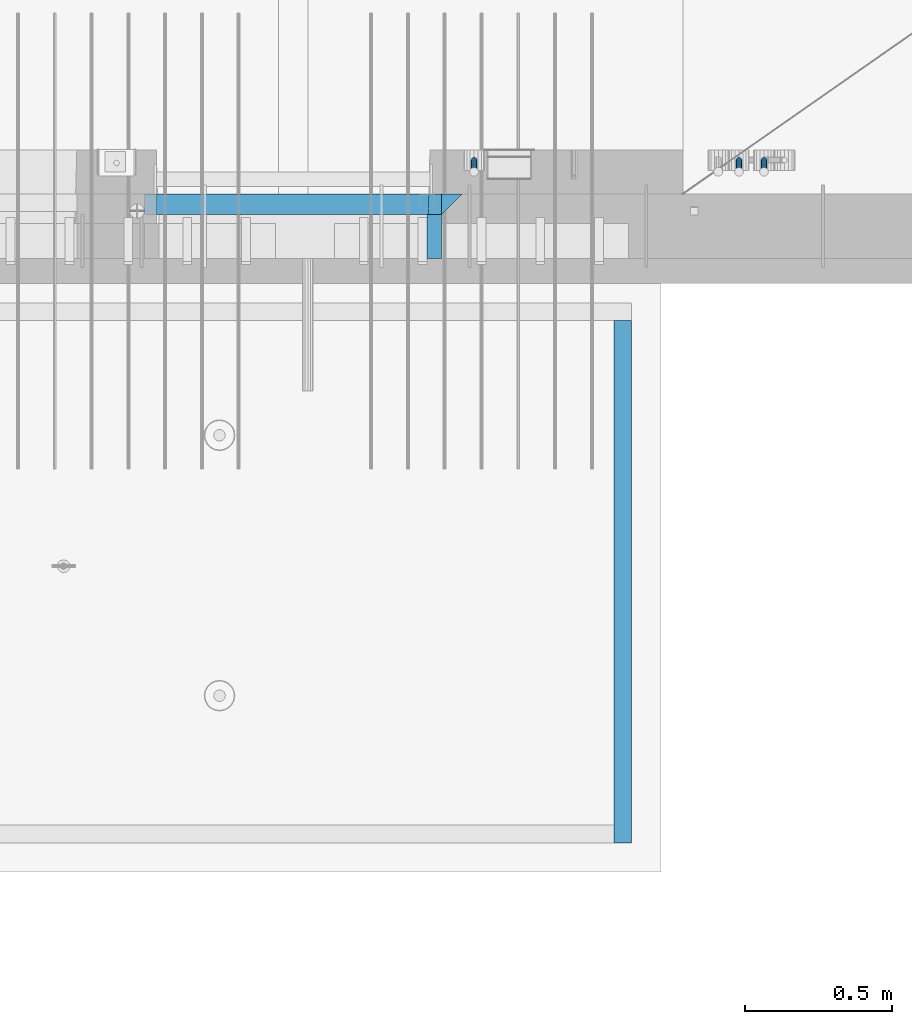
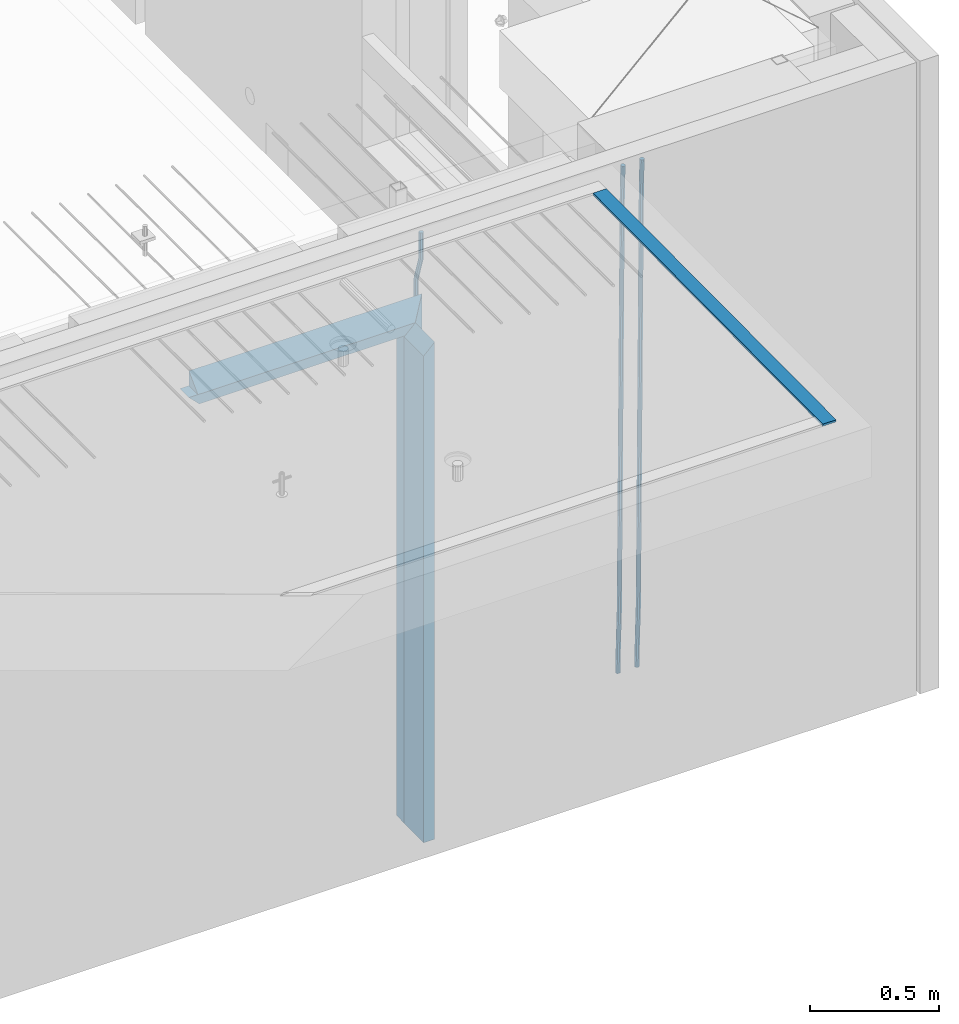
# One storey, part 123 of 334: 9 beams, 2 elements without a shape of their own.
"""IFC2X3 building model written with IfcOpenShell, lengths in millimetres."""

from ifc_helpers import new_model, si_unit, frame, origin_with_axes, place, context, subcontext, project, spatial, faceted_brep, material, type_object, element, aggregate, save


model = new_model("IFC2X3")

# Units and contexts
model_context = context("Model", 3, precision=1e-05, world=origin_with_axes())
body_context = subcontext(model_context, "Body", "Model", "MODEL_VIEW")
ifc_project = project(units=[si_unit("LENGTHUNIT", "METRE", prefix="MILLI"), si_unit("AREAUNIT", "SQUARE_METRE"), si_unit("VOLUMEUNIT", "CUBIC_METRE"), si_unit("MASSUNIT", "GRAM", prefix="KILO"), si_unit("TIMEUNIT", "SECOND"), si_unit("PLANEANGLEUNIT", "RADIAN"), si_unit("SOLIDANGLEUNIT", "STERADIAN"), si_unit("THERMODYNAMICTEMPERATUREUNIT", "DEGREE_CELSIUS"), si_unit("LUMINOUSINTENSITYUNIT", "LUMEN")], contexts=[model_context])

# Site, building, storey
site_placement = place(None, origin_with_axes())
site = spatial("IfcSite", under=ifc_project, at=site_placement, CompositionType="ELEMENT")
building_placement = place(site_placement, origin_with_axes())
building = spatial("IfcBuilding", under=site, at=building_placement, CompositionType="ELEMENT")
storey_placement = place(building_placement, origin_with_axes())
storey = spatial("IfcBuildingStorey", under=building, at=storey_placement, Name="3", CompositionType="ELEMENT", Elevation=0.0)

# Assembly, beams
assembly_1_placement = place(storey_placement, origin_with_axes())
assembly_1 = element("IfcElementAssembly", 1, at=assembly_1_placement, inside=storey, AssemblyPlace="NOTDEFINED", PredefinedType="REINFORCEMENT_UNIT")
ifc_material_1 = material(Name="CONCRETE/C35/45")
beam_type_1 = type_object("IfcBeamType", PredefinedType="NOTDEFINED")
beam_1_placement = place(assembly_1_placement, frame((32195.0011811506, 7815.0, 90140.0), z_axis=(0.0, 0.0, -1.0), x_axis=(1.0, 0.0, 0.0)))
beam_1 = element("IfcBeam", 2, at=beam_1_placement, type_object=beam_type_1, material=ifc_material_1, Name="SK", context=body_context, shape_type="Brep", body=[
    faceted_brep([(0.0, -35.0, 35.0), (0.0, 35.0, 35.0), (0.0, -35.0, -35.0), (1039.99771118164, -35.0, -35.0), (969.997711181637, -35.0, 35.0), (969.997711181637, 35.0, 35.0)], [[[0, 1, 2]], [[0, 2, 3, 4]], [[1, 0, 4, 5]], [[2, 1, 5, 3]], [[4, 3, 5]]]),
])
beam_2_placement = place(assembly_1_placement, frame((33199.9988923323, 7815.0, 90175.0), z_axis=(-1.0, 3.00000001838171e-08, 0.0), x_axis=(0.0, 0.0, -1.0)))
beam_2 = element("IfcBeam", 3, at=beam_2_placement, type_object=beam_type_1, material=ifc_material_1, Name="SK", context=body_context, shape_type="Brep", body=[
    faceted_brep([(2420.0, -35.0, 35.0), (2420.0, -35.0, -35.0), (2420.0, 35.0, 35.0), (0.0, -35.0, -35.0), (70.0000000000164, 35.0, 35.0), (70.0000000000164, -35.0, 35.0)], [[[0, 1, 2]], [[2, 1, 3, 4]], [[0, 2, 4, 5]], [[1, 0, 5, 3]], [[5, 4, 3]]]),
])
beam_type_2 = type_object("IfcBeamType", PredefinedType="NOTDEFINED")
beam_3_placement = place(assembly_1_placement, frame((32155.0011811506, 7815.0, 90080.0), z_axis=(0.0, 0.0, -1.0), x_axis=(1.0, 0.0, 0.0)))
beam_3 = element("IfcBeam", 4, at=beam_3_placement, type_object=beam_type_2, material=ifc_material_1, Name="SK", context=body_context, shape_type="Brep", body=[
    faceted_brep([(0.0, -35.0, -25.0), (43.8438650277967, -35.0, 18.8461538461561), (45.6387368226679, 35.0, 20.6410256410309), (0.0, 35.0, -25.0), (1009.99771118164, -35.0, -25.0), (966.151557335485, -35.0, 18.8461538461561), (964.356685540617, 35.0, 20.6410256410309), (1009.99771118164, 35.0, -25.0)], [[[0, 1, 2, 3]], [[1, 0, 4, 5]], [[2, 1, 5, 6]], [[3, 2, 6, 7]], [[0, 3, 7, 4]], [[6, 5, 4, 7]]]),
])
beam_4_placement = place(assembly_1_placement, frame((33139.9988923323, 7815.0, 90105.0), z_axis=(-1.0, 3.00000001838171e-08, 0.0), x_axis=(0.0, 0.0, -1.0)))
beam_4 = element("IfcBeam", 5, at=beam_4_placement, type_object=beam_type_2, material=ifc_material_1, Name="SK", context=body_context, shape_type="Brep", body=[
    faceted_brep([(2350.0, -35.0, -25.0), (2350.0, 35.0, -25.0), (2350.0, 35.0, 20.6410256410309), (2350.0, -35.0, 18.8461538461561), (0.0, -35.0, -25.0), (0.0, 35.0, -25.0), (45.6410256410309, 35.0, 20.6410256410254), (43.8461538461561, -35.0, 18.8461538461543)], [[[0, 1, 2, 3]], [[1, 0, 4, 5]], [[2, 1, 5, 6]], [[3, 2, 6, 7]], [[0, 3, 7, 4]], [[6, 5, 4, 7]]]),
])
ifc_material_2 = material(Name="TIMBER")
beam_type_3 = type_object("IfcBeamType", Name="50X150", PredefinedType="NOTDEFINED")
beam_5_placement = place(assembly_1_placement, frame((33139.9988923323, 7705.0, 90105.0), z_axis=(-1.0, 3.00000001838171e-08, 0.0), x_axis=(0.0, 0.0, -1.0)))
beam_5 = element("IfcBeam", 6, at=beam_5_placement, type_object=beam_type_3, material=ifc_material_2, ObjectType="50X150", context=body_context, shape_type="Brep", body=[
    faceted_brep([(2345.0, -75.0, 25.0), (2345.0, -75.0, -25.0), (2345.0, 75.0, -25.0), (2345.0, 75.0, 25.0), (0.0, -75.0, -25.0), (0.0, 75.0, -25.0), (50.0000000000036, 75.0, 25.0), (50.0000000000036, -75.0, 25.0)], [[[0, 1, 2, 3]], [[4, 5, 2, 1]], [[3, 2, 5, 6]], [[0, 3, 6, 7]], [[1, 0, 7, 4]], [[7, 6, 5, 4]]]),
])
ifc_material_3 = material()
beam_type_4 = type_object("IfcBeamType", Name="D20", PredefinedType="NOTDEFINED")
beam_6_placement = place(assembly_1_placement, frame((33274.9999999916, 7925.0, 90407.5), z_axis=(0.000415599999849905, 0.999999913638203, 4.76000000899737e-07), x_axis=(0.0, 0.0, -1.0)))
beam_6 = element("IfcBeam", 7, at=beam_6_placement, type_object=beam_type_4, material=ifc_material_3, Name="JM20", ObjectType="D20", context=body_context, shape_type="Brep", body=[
    faceted_brep([(0.0, -10.0, 0.0), (-4.19531716033816e-08, -7.07106781186667, -7.07106781187031), (113.248091332178, -7.0710684840451, -7.0710678117357), (113.248091314759, -10.0000006713562, -2.51020537689328e-10), (0.0, 0.0, -10.0), (113.248091374131, -6.72178430249915e-07, -9.99999999986903), (4.196772351861e-08, 7.07106781186303, -7.07106781186667), (113.248091416113, 7.07106713968824, -7.07106781173934), (0.0, 10.0, 0.0), (113.248091433488, 9.99999932782521, 1.30967237055302e-10), (4.196772351861e-08, 7.07106781185939, 7.07106781185939), (113.248091416113, 7.0710671396846, 7.071067811994), (0.0, 0.0, 10.0), (113.248091374131, -6.72174792271107e-07, 10.0000000001273), (-4.19531716033816e-08, -7.07106781187031, 7.07106781185939), (113.248091332178, -7.0710684840451, 7.071067811994), (130.699843527167, -7.06993249763036, -4.33745683788584), (128.538066582521, -9.99900540317321, 2.39499413731755), (131.594536475241, 0.00119355250353692, -7.12624594330919), (130.698046432328, 7.07220300913468, -4.33773834422391), (128.535525107087, 10.0009944322555, 2.39459602660281), (126.373748162892, 7.07192152754578, 9.1270470011732), (125.479055214906, 0.000795477419160306, 11.9158361066184), (126.37554525779, -7.07021397921199, 9.12732850753673), (240.336258550378, -7.05529970173666, 30.8729495437874), (238.174481606227, -9.98437260450009, 37.6054005176375), (241.230951498423, 0.0158263482953771, 28.0841604381058), (240.334461455612, 7.0868358050102, 30.8726680369582), (238.171940130502, 10.0156272283348, 37.6050024077231), (236.010163186409, 7.08655432384694, 44.3374533824244), (235.115470238379, 0.0154282738185429, 47.1262424881097), (236.011960281176, -7.05558118289991, 44.3377348892536), (253.461915329972, -7.05444528127919, 32.9289287376414), (253.46191532613, -9.98337746617108, 39.9999965521893), (253.461915339081, 0.0166225284556276, 29.9999965443676), (253.461915348205, 7.08769034247234, 32.9289287273205), (253.461915352003, 10.0166225357716, 39.9999965370152), (253.461915348293, 7.08769035281148, 47.0710643509774), (253.461915339183, 0.0166225430875784, 49.999996544273), (253.46191533003, -7.05444527093641, 47.0710643613093), (2417.50000002384, -7.0544364694706, 32.9289287374122), (2417.5000000337, -9.98336865393321, 39.9999965507959), (2417.49999999997, 0.0166313408753922, 29.9999965456082), (2417.49999997609, 7.08769915426274, 32.9289287300708), (2417.4999999662, 10.0166313460668, 39.9999965404204), (2417.49999997608, 7.08769916160054, 47.0710643538114), (2417.49999999994, 0.0166313512581837, 49.9999965456154), (2417.50000002382, -7.05443646212916, 47.0710643611455)], [[[0, 1, 2, 3]], [[1, 4, 5, 2]], [[4, 6, 7, 5]], [[6, 8, 9, 7]], [[8, 10, 11, 9]], [[10, 12, 13, 11]], [[12, 14, 15, 13]], [[14, 0, 3, 15]], [[14, 12, 10, 8, 6, 4, 1, 0]], [[3, 2, 16, 17]], [[2, 5, 18, 16]], [[5, 7, 19, 18]], [[7, 9, 20, 19]], [[9, 11, 21, 20]], [[11, 13, 22, 21]], [[13, 15, 23, 22]], [[15, 3, 17, 23]], [[17, 16, 24, 25]], [[16, 18, 26, 24]], [[18, 19, 27, 26]], [[19, 20, 28, 27]], [[20, 21, 29, 28]], [[21, 22, 30, 29]], [[22, 23, 31, 30]], [[23, 17, 25, 31]], [[25, 24, 32, 33]], [[24, 26, 34, 32]], [[26, 27, 35, 34]], [[27, 28, 36, 35]], [[28, 29, 37, 36]], [[29, 30, 38, 37]], [[30, 31, 39, 38]], [[31, 25, 33, 39]], [[33, 32, 40, 41]], [[32, 34, 42, 40]], [[34, 35, 43, 42]], [[35, 36, 44, 43]], [[36, 37, 45, 44]], [[37, 38, 46, 45]], [[38, 39, 47, 46]], [[39, 33, 41, 47]], [[42, 43, 44, 45, 46, 47, 41, 40]]]),
])
beam_7_placement = place(assembly_1_placement, frame((34259.9999999961, 7965.00000227913, 87990.0), z_axis=(0.00020576299992186, -0.999642804629538, -0.0267249099901004), x_axis=(-4.30000201928125e-08, -0.0267249099948059, 0.999642825806181)))
beam_7 = element("IfcBeam", 8, at=beam_7_placement, type_object=beam_type_4, material=ifc_material_3, Name="JM20", ObjectType="D20", context=body_context, shape_type="Brep", body=[
    faceted_brep([(0.0, -10.0, 0.0), (-4.19531716033816e-08, -7.07106781186667, -7.07106781187031), (60.4266690400545, -7.0710677960451, -7.07106780570757), (60.4266690441291, -9.99999998418934, 6.15546014159918e-09), (0.0, 0.0, -10.0), (60.426669036824, 1.58106558956206e-08, -9.99999999384454), (4.196772351861e-08, 7.07106781186303, -7.07106781186667), (60.4266690363438, 7.07106782768096, -7.07106780570757), (0.0, 10.0, 0.0), (60.4266690388904, 10.0000000158179, 6.15182216279209e-09), (4.196772351861e-08, 7.07106781185939, 7.07106781185939), (60.4266690429649, 7.07106782768096, 7.07106781802577), (0.0, 0.0, 10.0), (60.4266690461809, 1.58179318532348e-08, 10.0000000061555), (-4.19531716033816e-08, -7.07106781187031, 7.07106781185939), (60.4266690466611, -7.07106779605238, 7.07106781802213), (61.0378400410118, -7.07106779588503, -7.07106780564936), (60.991799419251, -9.99999998403655, 6.21366780251265e-09), (61.0569027789461, 1.5985278878361e-08, -9.99999999378269), (61.0378209396877, 7.07106782784831, -7.07106780564936), (60.9917724058905, 10.0000000159635, 6.21366780251265e-09), (60.9457317841297, 7.07106782781193, 7.0710678180767), (60.9266690461809, 1.59488990902901e-08, 10.0000000062028), (60.9457508854539, -7.07106779591413, 7.0710678180767), (61.6489592143771, -7.07106614513759, -7.06310863441468), (61.5568818710308, -9.9999984576425, 0.00735959856683621), (61.6870830769039, 1.71821739058942e-06, -9.99179257185824), (61.6489210170112, 7.07106947854481, -7.06310888312146), (61.556827851804, 10.0000015422847, 0.00735924683976918), (61.4647505084577, 7.07106922979438, 7.07782747982128), (61.4266266459163, 1.36643211590126e-06, 10.0065114172685), (61.464788705809, -7.07106639389531, 7.07782772852806), (176.543135720174, -7.07075579406956, -5.56673531796696), (176.451058376813, -9.99968810657447, 1.50373291501455), (176.581259582701, 0.000312069292704109, -8.49541925541052), (176.543097522794, 7.07137982961285, -5.56673556667374), (176.451004357587, 10.00031189336, 1.50373256329476), (176.35892701424, 7.07137958085514, 8.57420079627263), (176.320803151699, 0.000311717507429421, 11.5028847337162), (176.358965211621, -7.07075604281999, 8.57420104497578), (177.098753836006, -7.07075429323595, -5.55949898843028), (176.98362511232, -9.99968666800123, 1.510669025065), (177.146421932586, 0.000313595905026887, -8.48805862247536), (177.098706077581, 7.07138133041735, -5.55949936166144), (176.983557571715, 10.0003133318824, 1.51066849724157), (176.868428848029, 7.07138095712435, 8.58083651073321), (176.820760751449, 0.000313067976094317, 11.5093961447819), (176.868476606425, -7.07075466652896, 8.58083688396073), (177.654312950661, -7.07075204110879, -5.54863964998367), (177.516135294456, -9.99968450931192, 1.52107783331303), (177.711524267797, 0.000315886711177882, -8.47701274570863), (177.654255632195, 7.07138358250813, -5.54864021007961), (177.516054233929, 10.0003154905207, 1.5210770412159), (177.377876577739, 7.0713830223176, 8.59079452451624), (177.320665260588, 0.000315094497636892, 11.5191676202448), (177.377933896176, -7.07075260129932, 8.59079508461218), (299.436796249574, -7.07025836271714, -3.1681962331204), (299.298618593355, -9.99919083092027, 3.90152125031091), (299.494007566798, 0.000809565110102994, -6.09656932889993), (299.436738931283, 7.07187726089978, -3.16819679320906), (299.298537533061, 10.0008091689197, 3.90152045822106), (299.160359876842, 7.07187670072017, 10.9712379416487), (299.103148559603, 0.000808772889286047, 13.8996110374392), (299.160417195119, -7.07025892290039, 10.9712385017483), (299.98743051647, -7.07025613056248, -3.15743315966392), (299.971788958996, -9.99918809853989, 3.91467979818117), (299.993912075952, 0.000811591617093654, -6.08679785393178), (299.987423933868, 7.07187949325817, -3.1574327280432), (299.971753863239, 10.0008119014747, 3.91467990454839), (299.95611230444, 7.07187992653053, 10.9867922621015), (299.949630744944, 0.000812204350950196, 13.9161569563694), (299.956118887014, -7.07025569729012, 10.9867918304735), (300.538107039494, -7.07025785017686, -3.16575821840888), (300.644985195438, -9.99919020432935, 3.90450175465594), (300.493854948218, 0.000810030429420294, -6.09435592770024), (300.538151196495, 7.071877773491, -3.16575855385963), (300.645047642858, 10.0008097955724, 3.90450128024895), (300.751925798773, 7.07187744142357, 10.9747612533101), (300.796177890064, 0.000809560813650023, 13.9033589625978), (300.751881641787, -7.07025818224065, 10.9747615887682), (2293.36490490142, -7.07648090940347, -33.2930642912361), (2293.47178305736, -10.0054132635523, -26.2228043181785), (2293.32065281013, -0.00541302880083094, -36.2216620005347), (2293.36494905842, 7.06565471425711, -33.2930646266868), (2293.47184550477, 9.99458673634581, -26.2228047925819), (2293.57872366071, 7.06565438219332, -19.1525448195243), (2293.62297575199, -0.00541349841296324, -16.2239471102366), (2293.57867950371, -7.0764812414709, -19.1525444840736), (2294.0658245362, -7.07648309818615, -33.3036607065333), (2294.05312277409, -10.0054150789219, -26.2315929392535), (2294.10928714235, -0.00541549149056664, -36.2335844756526), (2294.15805078732, 7.06565223761572, -33.3050546393533), (2294.18355038921, 9.99458451388637, -26.2335642579346), (2294.17084862708, 7.06565253314329, -19.1614964906439), (2294.12738602093, -0.00541507354500936, -16.2315727215355), (2294.07862237596, -7.07648280265857, -19.1601025578348), (2294.76670261032, -7.08562269121467, -33.294332712383), (2294.63442802057, -10.0129954178956, -26.2238563411993), (2294.89787471293, -0.0156988342423574, -36.2230891548279), (2294.95110548967, 7.05531064255774, -33.2944998654275), (2294.89521307347, 9.98530428734011, -26.2240927312887), (2294.76293848372, 7.0579315606592, -19.1536163601049), (2294.63176638114, -0.0119922963167483, -16.2248599176673), (2294.57853560438, -7.08300177311321, -19.1534492070678), (2316.52657204497, -7.36937582653991, -33.0047303660212), (2316.39429745522, -10.2967485532172, -25.9342539948302), (2316.65774414754, -0.299451969567599, -35.9334868084661), (2316.7109749243, 6.7715575072325, -33.0048975190657), (2316.65508250811, 9.70155115201487, -25.9344903849269), (2316.52280791836, 6.7741784253376, -18.8640140137468), (2316.39163581574, -0.295745431634714, -15.9352575713092), (2316.33840503903, -7.36675490843481, -18.863846860706), (2317.16202064224, -7.37766220584308, -32.9962731735213), (2317.05438744847, -10.3053562613532, -25.9254688497131), (2317.23607125619, -0.306993473008333, -35.925789846493), (2317.23316144495, 6.76474808850253, -32.9979477328052), (2317.15499573652, 9.6950321815566, -25.9278370341635), (2317.04736254275, 6.7673381260538, -18.8570327103698), (2316.97331192881, -0.303330606784584, -15.9275160373909), (2316.97622174003, -7.37507216829545, -18.8553581510787), (2317.79752306276, -7.37578610372293, -32.9880110666527), (2317.71453320107, -10.3033876998124, -25.9168792378296), (2317.81444760226, -0.305295583297266, -35.918287695793), (2317.75539265381, 6.76628640723357, -32.9911928173897), (2317.65495180529, 9.69652304524061, -25.9213789128698), (2317.5719619436, 6.76892144914746, -18.8502470840467), (2317.55503740412, -0.301569071270933, -15.9199704549137), (2317.61409235255, -7.3731510618054, -18.847065333317), (2417.8183084176, -7.07752398473531, -31.6906369377139), (2417.73531855589, -10.0051255808248, -24.6195051088798), (2417.83523295709, -0.007033464313281, -34.6209135668432), (2417.77617800863, 7.06454852621755, -31.6938186884508), (2417.67573716014, 9.99478516423187, -24.6240047839383), (2417.59274729842, 7.06718356813872, -17.5528729551006), (2417.57582275895, -0.00330695228694822, -14.6225963259749), (2417.6348777074, -7.07488894281778, -17.5496912043673)], [[[0, 1, 2, 3]], [[1, 4, 5, 2]], [[4, 6, 7, 5]], [[6, 8, 9, 7]], [[8, 10, 11, 9]], [[10, 12, 13, 11]], [[12, 14, 15, 13]], [[14, 0, 3, 15]], [[14, 12, 10, 8, 6, 4, 1, 0]], [[3, 2, 16, 17]], [[2, 5, 18, 16]], [[5, 7, 19, 18]], [[7, 9, 20, 19]], [[9, 11, 21, 20]], [[11, 13, 22, 21]], [[13, 15, 23, 22]], [[15, 3, 17, 23]], [[17, 16, 24, 25]], [[16, 18, 26, 24]], [[18, 19, 27, 26]], [[19, 20, 28, 27]], [[20, 21, 29, 28]], [[21, 22, 30, 29]], [[22, 23, 31, 30]], [[23, 17, 25, 31]], [[25, 24, 32, 33]], [[24, 26, 34, 32]], [[26, 27, 35, 34]], [[27, 28, 36, 35]], [[28, 29, 37, 36]], [[29, 30, 38, 37]], [[30, 31, 39, 38]], [[31, 25, 33, 39]], [[33, 32, 40, 41]], [[32, 34, 42, 40]], [[34, 35, 43, 42]], [[35, 36, 44, 43]], [[36, 37, 45, 44]], [[37, 38, 46, 45]], [[38, 39, 47, 46]], [[39, 33, 41, 47]], [[41, 40, 48, 49]], [[40, 42, 50, 48]], [[42, 43, 51, 50]], [[43, 44, 52, 51]], [[44, 45, 53, 52]], [[45, 46, 54, 53]], [[46, 47, 55, 54]], [[47, 41, 49, 55]], [[49, 48, 56, 57]], [[48, 50, 58, 56]], [[50, 51, 59, 58]], [[51, 52, 60, 59]], [[52, 53, 61, 60]], [[53, 54, 62, 61]], [[54, 55, 63, 62]], [[55, 49, 57, 63]], [[57, 56, 64, 65]], [[56, 58, 66, 64]], [[58, 59, 67, 66]], [[59, 60, 68, 67]], [[60, 61, 69, 68]], [[61, 62, 70, 69]], [[62, 63, 71, 70]], [[63, 57, 65, 71]], [[65, 64, 72, 73]], [[64, 66, 74, 72]], [[66, 67, 75, 74]], [[67, 68, 76, 75]], [[68, 69, 77, 76]], [[69, 70, 78, 77]], [[70, 71, 79, 78]], [[71, 65, 73, 79]], [[73, 72, 80, 81]], [[72, 74, 82, 80]], [[74, 75, 83, 82]], [[75, 76, 84, 83]], [[76, 77, 85, 84]], [[77, 78, 86, 85]], [[78, 79, 87, 86]], [[79, 73, 81, 87]], [[81, 80, 88, 89]], [[80, 82, 90, 88]], [[82, 83, 91, 90]], [[83, 84, 92, 91]], [[84, 85, 93, 92]], [[85, 86, 94, 93]], [[86, 87, 95, 94]], [[87, 81, 89, 95]], [[89, 88, 96, 97]], [[88, 90, 98, 96]], [[90, 91, 99, 98]], [[91, 92, 100, 99]], [[92, 93, 101, 100]], [[93, 94, 102, 101]], [[94, 95, 103, 102]], [[95, 89, 97, 103]], [[97, 96, 104, 105]], [[96, 98, 106, 104]], [[98, 99, 107, 106]], [[99, 100, 108, 107]], [[100, 101, 109, 108]], [[101, 102, 110, 109]], [[102, 103, 111, 110]], [[103, 97, 105, 111]], [[105, 104, 112, 113]], [[104, 106, 114, 112]], [[106, 107, 115, 114]], [[107, 108, 116, 115]], [[108, 109, 117, 116]], [[109, 110, 118, 117]], [[110, 111, 119, 118]], [[111, 105, 113, 119]], [[113, 112, 120, 121]], [[112, 114, 122, 120]], [[114, 115, 123, 122]], [[115, 116, 124, 123]], [[116, 117, 125, 124]], [[117, 118, 126, 125]], [[118, 119, 127, 126]], [[119, 113, 121, 127]], [[121, 120, 128, 129]], [[120, 122, 130, 128]], [[122, 123, 131, 130]], [[123, 124, 132, 131]], [[124, 125, 133, 132]], [[125, 126, 134, 133]], [[126, 127, 135, 134]], [[127, 121, 129, 135]], [[130, 131, 132, 133, 134, 135, 129, 128]]]),
])
beam_8_placement = place(assembly_1_placement, frame((34174.9999999961, 7965.00000227913, 87990.0), z_axis=(0.00020576299992186, -0.999642804629538, -0.0267249099901004), x_axis=(-4.30000201928125e-08, -0.0267249099948059, 0.999642825806181)))
beam_8 = element("IfcBeam", 9, at=beam_8_placement, type_object=beam_type_4, material=ifc_material_3, Name="JM20", ObjectType="D20", context=body_context, shape_type="Brep", body=[
    faceted_brep([(0.0, -10.0, 0.0), (-4.19531716033816e-08, -7.07106781186667, -7.07106781187031), (60.4266690400545, -7.0710677960451, -7.07106780570757), (60.4266690441291, -9.99999998418934, 6.15546014159918e-09), (0.0, 0.0, -10.0), (60.426669036824, 1.58106558956206e-08, -9.99999999384454), (4.196772351861e-08, 7.07106781186303, -7.07106781186667), (60.4266690363438, 7.07106782768096, -7.07106780570757), (0.0, 10.0, 0.0), (60.4266690388904, 10.0000000158179, 6.15182216279209e-09), (4.196772351861e-08, 7.07106781185939, 7.07106781185939), (60.4266690429649, 7.07106782768096, 7.07106781802577), (0.0, 0.0, 10.0), (60.4266690461809, 1.58179318532348e-08, 10.0000000061555), (-4.19531716033816e-08, -7.07106781187031, 7.07106781185939), (60.4266690466611, -7.07106779605238, 7.07106781802213), (61.0378400410118, -7.07106779588503, -7.07106780564936), (60.991799419251, -9.99999998403655, 6.21366780251265e-09), (61.0569027789461, 1.5985278878361e-08, -9.99999999378269), (61.0378209396877, 7.07106782784831, -7.07106780564936), (60.9917724058905, 10.0000000159635, 6.21366780251265e-09), (60.9457317841297, 7.07106782781193, 7.0710678180767), (60.9266690461809, 1.59488990902901e-08, 10.0000000062028), (60.9457508854539, -7.07106779591413, 7.0710678180767), (61.6489592143771, -7.07106614513759, -7.06310863441468), (61.5568818710308, -9.9999984576425, 0.00735959856683621), (61.6870830769039, 1.71821739058942e-06, -9.99179257185824), (61.6489210170112, 7.07106947854481, -7.06310888312146), (61.556827851804, 10.0000015422847, 0.00735924683976918), (61.4647505084577, 7.07106922979438, 7.07782747982128), (61.4266266459163, 1.36643211590126e-06, 10.0065114172685), (61.464788705809, -7.07106639389531, 7.07782772852806), (176.543135720174, -7.07075579406956, -5.56673531796696), (176.451058376813, -9.99968810657447, 1.50373291501455), (176.581259582701, 0.000312069292704109, -8.49541925541052), (176.543097522794, 7.07137982961285, -5.56673556667374), (176.451004357587, 10.00031189336, 1.50373256329476), (176.35892701424, 7.07137958085514, 8.57420079627263), (176.320803151699, 0.000311717507429421, 11.5028847337162), (176.358965211621, -7.07075604281999, 8.57420104497578), (177.098753836006, -7.07075429323595, -5.55949898843028), (176.98362511232, -9.99968666800123, 1.510669025065), (177.146421932586, 0.000313595905026887, -8.48805862247536), (177.098706077581, 7.07138133041735, -5.55949936166144), (176.983557571715, 10.0003133318824, 1.51066849724157), (176.868428848029, 7.07138095712435, 8.58083651073321), (176.820760751449, 0.000313067976094317, 11.5093961447819), (176.868476606425, -7.07075466652896, 8.58083688396073), (177.654312950661, -7.07075204110879, -5.54863964998367), (177.516135294456, -9.99968450931192, 1.52107783331303), (177.711524267797, 0.000315886711177882, -8.47701274570863), (177.654255632195, 7.07138358250813, -5.54864021007961), (177.516054233929, 10.0003154905207, 1.5210770412159), (177.377876577739, 7.0713830223176, 8.59079452451624), (177.320665260588, 0.000315094497636892, 11.5191676202448), (177.377933896176, -7.07075260129932, 8.59079508461218), (299.436796249574, -7.07025836271714, -3.1681962331204), (299.298618593355, -9.99919083092027, 3.90152125031091), (299.494007566798, 0.000809565110102994, -6.09656932889993), (299.436738931283, 7.07187726089978, -3.16819679320906), (299.298537533061, 10.0008091689197, 3.90152045822106), (299.160359876842, 7.07187670072017, 10.9712379416487), (299.103148559603, 0.000808772889286047, 13.8996110374392), (299.160417195119, -7.07025892290039, 10.9712385017483), (299.98743051647, -7.07025613056248, -3.15743315966392), (299.971788958996, -9.99918809853989, 3.91467979818117), (299.993912075952, 0.000811591617093654, -6.08679785393178), (299.987423933868, 7.07187949325817, -3.1574327280432), (299.971753863239, 10.0008119014747, 3.91467990454839), (299.95611230444, 7.07187992653053, 10.9867922621015), (299.949630744944, 0.000812204350950196, 13.9161569563694), (299.956118887014, -7.07025569729012, 10.9867918304735), (300.538107039494, -7.07025785017686, -3.16575821840888), (300.644985195438, -9.99919020432935, 3.90450175465594), (300.493854948218, 0.000810030429420294, -6.09435592770024), (300.538151196495, 7.071877773491, -3.16575855385963), (300.645047642858, 10.0008097955724, 3.90450128024895), (300.751925798773, 7.07187744142357, 10.9747612533101), (300.796177890064, 0.000809560813650023, 13.9033589625978), (300.751881641787, -7.07025818224065, 10.9747615887682), (2293.36490490142, -7.07648090940347, -33.2930642912361), (2293.47178305736, -10.0054132635523, -26.2228043181785), (2293.32065281013, -0.00541302880083094, -36.2216620005347), (2293.36494905842, 7.06565471425711, -33.2930646266868), (2293.47184550477, 9.99458673634581, -26.2228047925819), (2293.57872366071, 7.06565438219332, -19.1525448195243), (2293.62297575199, -0.00541349841296324, -16.2239471102366), (2293.57867950371, -7.0764812414709, -19.1525444840736), (2294.0658245362, -7.07648309818615, -33.3036607065333), (2294.05312277409, -10.0054150789219, -26.2315929392535), (2294.10928714235, -0.00541549149056664, -36.2335844756526), (2294.15805078732, 7.06565223761572, -33.3050546393533), (2294.18355038921, 9.99458451388637, -26.2335642579346), (2294.17084862708, 7.06565253314329, -19.1614964906439), (2294.12738602093, -0.00541507354500936, -16.2315727215355), (2294.07862237596, -7.07648280265857, -19.1601025578348), (2294.76670261032, -7.08562269121467, -33.294332712383), (2294.63442802057, -10.0129954178956, -26.2238563411993), (2294.89787471293, -0.0156988342423574, -36.2230891548279), (2294.95110548967, 7.05531064255774, -33.2944998654275), (2294.89521307347, 9.98530428734011, -26.2240927312887), (2294.76293848372, 7.0579315606592, -19.1536163601049), (2294.63176638114, -0.0119922963167483, -16.2248599176673), (2294.57853560438, -7.08300177311321, -19.1534492070678), (2316.52657204497, -7.36937582653991, -33.0047303660212), (2316.39429745522, -10.2967485532172, -25.9342539948302), (2316.65774414754, -0.299451969567599, -35.9334868084661), (2316.7109749243, 6.7715575072325, -33.0048975190657), (2316.65508250811, 9.70155115201487, -25.9344903849269), (2316.52280791836, 6.7741784253376, -18.8640140137468), (2316.39163581574, -0.295745431634714, -15.9352575713092), (2316.33840503903, -7.36675490843481, -18.863846860706), (2317.16202064224, -7.37766220584308, -32.9962731735213), (2317.05438744847, -10.3053562613532, -25.9254688497131), (2317.23607125619, -0.306993473008333, -35.925789846493), (2317.23316144495, 6.76474808850253, -32.9979477328052), (2317.15499573652, 9.6950321815566, -25.9278370341635), (2317.04736254275, 6.7673381260538, -18.8570327103698), (2316.97331192881, -0.303330606784584, -15.9275160373909), (2316.97622174003, -7.37507216829545, -18.8553581510787), (2317.79752306276, -7.37578610372293, -32.9880110666527), (2317.71453320107, -10.3033876998124, -25.9168792378296), (2317.81444760226, -0.305295583297266, -35.918287695793), (2317.75539265381, 6.76628640723357, -32.9911928173897), (2317.65495180529, 9.69652304524061, -25.9213789128698), (2317.5719619436, 6.76892144914746, -18.8502470840467), (2317.55503740412, -0.301569071270933, -15.9199704549137), (2317.61409235255, -7.3731510618054, -18.847065333317), (2417.8183084176, -7.07752398473531, -31.6906369377139), (2417.73531855589, -10.0051255808248, -24.6195051088798), (2417.83523295709, -0.007033464313281, -34.6209135668432), (2417.77617800863, 7.06454852621755, -31.6938186884508), (2417.67573716014, 9.99478516423187, -24.6240047839383), (2417.59274729842, 7.06718356813872, -17.5528729551006), (2417.57582275895, -0.00330695228694822, -14.6225963259749), (2417.6348777074, -7.07488894281778, -17.5496912043673)], [[[0, 1, 2, 3]], [[1, 4, 5, 2]], [[4, 6, 7, 5]], [[6, 8, 9, 7]], [[8, 10, 11, 9]], [[10, 12, 13, 11]], [[12, 14, 15, 13]], [[14, 0, 3, 15]], [[14, 12, 10, 8, 6, 4, 1, 0]], [[3, 2, 16, 17]], [[2, 5, 18, 16]], [[5, 7, 19, 18]], [[7, 9, 20, 19]], [[9, 11, 21, 20]], [[11, 13, 22, 21]], [[13, 15, 23, 22]], [[15, 3, 17, 23]], [[17, 16, 24, 25]], [[16, 18, 26, 24]], [[18, 19, 27, 26]], [[19, 20, 28, 27]], [[20, 21, 29, 28]], [[21, 22, 30, 29]], [[22, 23, 31, 30]], [[23, 17, 25, 31]], [[25, 24, 32, 33]], [[24, 26, 34, 32]], [[26, 27, 35, 34]], [[27, 28, 36, 35]], [[28, 29, 37, 36]], [[29, 30, 38, 37]], [[30, 31, 39, 38]], [[31, 25, 33, 39]], [[33, 32, 40, 41]], [[32, 34, 42, 40]], [[34, 35, 43, 42]], [[35, 36, 44, 43]], [[36, 37, 45, 44]], [[37, 38, 46, 45]], [[38, 39, 47, 46]], [[39, 33, 41, 47]], [[41, 40, 48, 49]], [[40, 42, 50, 48]], [[42, 43, 51, 50]], [[43, 44, 52, 51]], [[44, 45, 53, 52]], [[45, 46, 54, 53]], [[46, 47, 55, 54]], [[47, 41, 49, 55]], [[49, 48, 56, 57]], [[48, 50, 58, 56]], [[50, 51, 59, 58]], [[51, 52, 60, 59]], [[52, 53, 61, 60]], [[53, 54, 62, 61]], [[54, 55, 63, 62]], [[55, 49, 57, 63]], [[57, 56, 64, 65]], [[56, 58, 66, 64]], [[58, 59, 67, 66]], [[59, 60, 68, 67]], [[60, 61, 69, 68]], [[61, 62, 70, 69]], [[62, 63, 71, 70]], [[63, 57, 65, 71]], [[65, 64, 72, 73]], [[64, 66, 74, 72]], [[66, 67, 75, 74]], [[67, 68, 76, 75]], [[68, 69, 77, 76]], [[69, 70, 78, 77]], [[70, 71, 79, 78]], [[71, 65, 73, 79]], [[73, 72, 80, 81]], [[72, 74, 82, 80]], [[74, 75, 83, 82]], [[75, 76, 84, 83]], [[76, 77, 85, 84]], [[77, 78, 86, 85]], [[78, 79, 87, 86]], [[79, 73, 81, 87]], [[81, 80, 88, 89]], [[80, 82, 90, 88]], [[82, 83, 91, 90]], [[83, 84, 92, 91]], [[84, 85, 93, 92]], [[85, 86, 94, 93]], [[86, 87, 95, 94]], [[87, 81, 89, 95]], [[89, 88, 96, 97]], [[88, 90, 98, 96]], [[90, 91, 99, 98]], [[91, 92, 100, 99]], [[92, 93, 101, 100]], [[93, 94, 102, 101]], [[94, 95, 103, 102]], [[95, 89, 97, 103]], [[97, 96, 104, 105]], [[96, 98, 106, 104]], [[98, 99, 107, 106]], [[99, 100, 108, 107]], [[100, 101, 109, 108]], [[101, 102, 110, 109]], [[102, 103, 111, 110]], [[103, 97, 105, 111]], [[105, 104, 112, 113]], [[104, 106, 114, 112]], [[106, 107, 115, 114]], [[107, 108, 116, 115]], [[108, 109, 117, 116]], [[109, 110, 118, 117]], [[110, 111, 119, 118]], [[111, 105, 113, 119]], [[113, 112, 120, 121]], [[112, 114, 122, 120]], [[114, 115, 123, 122]], [[115, 116, 124, 123]], [[116, 117, 125, 124]], [[117, 118, 126, 125]], [[118, 119, 127, 126]], [[119, 113, 121, 127]], [[121, 120, 128, 129]], [[120, 122, 130, 128]], [[122, 123, 131, 130]], [[123, 124, 132, 131]], [[124, 125, 133, 132]], [[125, 126, 134, 133]], [[126, 127, 135, 134]], [[127, 121, 129, 135]], [[130, 131, 132, 133, 134, 135, 129, 128]]]),
])
aggregate(assembly_1, [beam_6, beam_7, beam_8, beam_1, beam_3, beam_2, beam_4, beam_5])

# Assembly, beam
assembly_2_placement = place(storey_placement, origin_with_axes())
assembly_2 = element("IfcElementAssembly", 10, at=assembly_2_placement, inside=storey, AssemblyPlace="NOTDEFINED", PredefinedType="REINFORCEMENT_UNIT")
ifc_material_4 = material(Name="CONCRETE/Concrete_Undefined")
beam_type_5 = type_object("IfcBeamType", PredefinedType="NOTDEFINED")
beam_9_placement = place(assembly_2_placement, frame((33780.0013901203, 7419.93652486339, 90725.2790080719), z_axis=(-6.00000203029786e-09, -0.00804209299877136, 0.999967661847222), x_axis=(-7.03000001873964e-07, -0.999967661846975, -0.00804209299876581)))
beam_9 = element("IfcBeam", 11, at=beam_9_placement, type_object=beam_type_5, material=ifc_material_4, context=body_context, shape_type="Brep", body=[
    faceted_brep([(2.5465851649642e-11, 29.9999999999982, -4.99999999998545), (-2.91038304567337e-11, 29.9999999999982, 5.0), (1775.0814268316, 30.0000000000073, 4.99999999998545), (1775.0814268316, 30.0000000000073, -5.00000000001455), (-2.5465851649642e-11, -30.0000000000018, 5.0), (1775.0814268316, -29.9999999999927, 5.0), (2.72848410531878e-11, -30.0000000000018, -4.99999999998545), (1775.0814268316, -29.9999999999927, -5.00000000001455)], [[[0, 1, 2, 3]], [[1, 4, 5, 2]], [[4, 6, 7, 5]], [[6, 0, 3, 7]], [[5, 7, 3, 2]], [[6, 4, 1, 0]]]),
])
aggregate(assembly_2, [beam_9])

save(model, "model.ifc")
